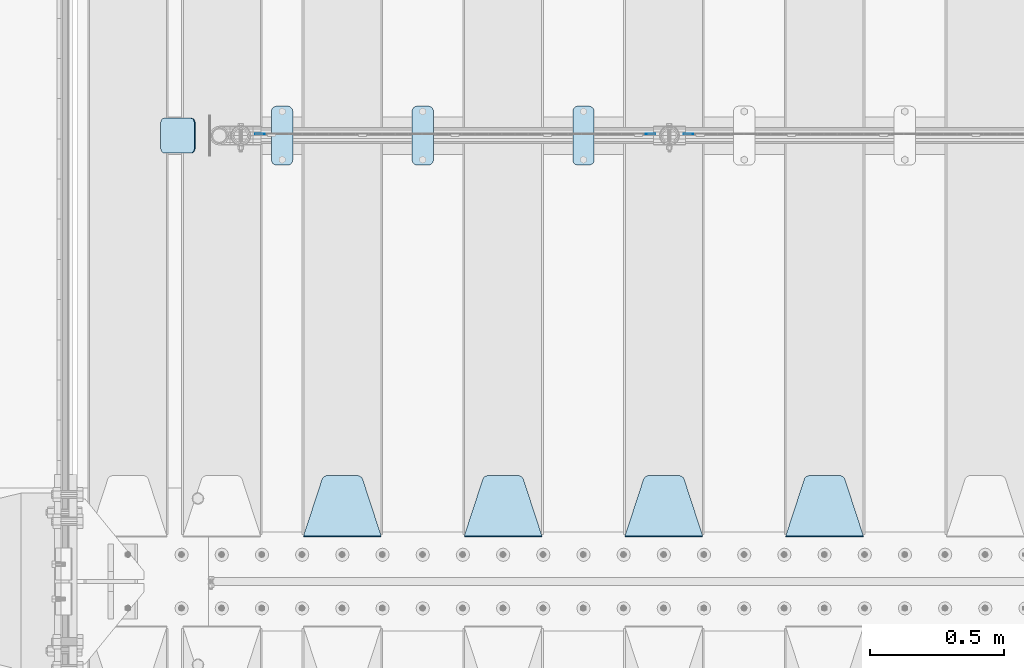
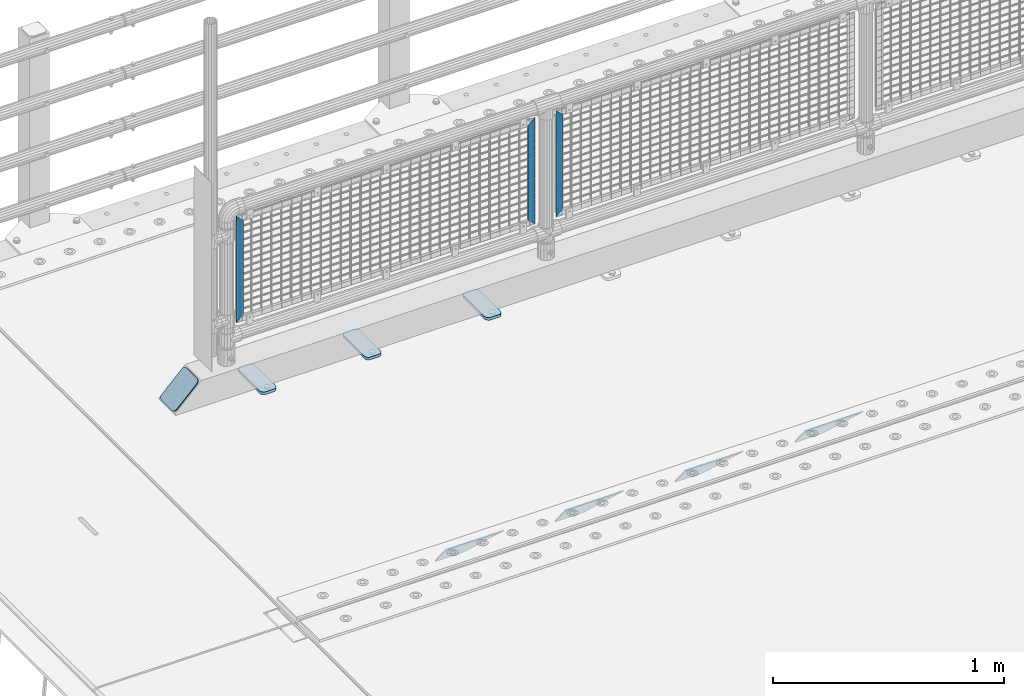
# One storey, part 218 of 257: 11 plates.
"""IFC2X3 building model written with IfcOpenShell, lengths in millimetres."""

from ifc_helpers import new_model, si_unit, frame, origin_with_axes, place, context, subcontext, project, spatial, faceted_brep, material, type_object, element, save


model = new_model("IFC2X3")

# Units and contexts
model_context = context("Model", 3, precision=1e-05, world=origin_with_axes())
body_context = subcontext(model_context, "Body", "Model", "MODEL_VIEW")
ifc_project = project(units=[si_unit("LENGTHUNIT", "METRE", prefix="MILLI"), si_unit("AREAUNIT", "SQUARE_METRE"), si_unit("VOLUMEUNIT", "CUBIC_METRE"), si_unit("MASSUNIT", "GRAM", prefix="KILO"), si_unit("TIMEUNIT", "SECOND"), si_unit("PLANEANGLEUNIT", "RADIAN"), si_unit("SOLIDANGLEUNIT", "STERADIAN"), si_unit("THERMODYNAMICTEMPERATUREUNIT", "DEGREE_CELSIUS"), si_unit("LUMINOUSINTENSITYUNIT", "LUMEN")], contexts=[model_context])

# Site, building, storey
site_placement = place(None, origin_with_axes())
site = spatial("IfcSite", under=ifc_project, at=site_placement, CompositionType="ELEMENT")
building_placement = place(site_placement, origin_with_axes())
building = spatial("IfcBuilding", under=site, at=building_placement, Name="Standard", CompositionType="ELEMENT")
storey_placement = place(building_placement, origin_with_axes())
storey = spatial("IfcBuildingStorey", under=building, at=storey_placement, Name="Undefined", CompositionType="ELEMENT", Elevation=0.0)

# Plates
ifc_material_1 = material(Name="STEEL/S355J2")
plate_type_1 = type_object("IfcPlateType", PredefinedType="NOTDEFINED")
plate_1_placement = place(storey_placement, frame((44310.0, 10774.5, 21.0199999999977), z_axis=(1.0, 0.0, 0.0), x_axis=(0.0, -1.0, 0.0)))
element("IfcPlate", 1, at=plate_1_placement, inside=storey, type_object=plate_type_1, material=ifc_material_1, context=body_context, shape_type="Brep", body=[
    faceted_brep([(0.0, -7.0, 20.0), (0.0, -7.0, 60.0), (0.0, 7.0, 60.0), (0.0, 7.0, 20.0), (0.384294391935327, -7.0, 63.9018064403208), (0.384294391935327, 7.0, 63.9018064403208), (1.52240934977453, -7.0, 67.6536686473046), (1.52240934977453, 7.0, 67.6536686473046), (3.37060775394821, -7.0, 71.1114046603907), (3.37060775394821, 7.0, 71.1114046603907), (5.85786437626848, -7.0, 74.1421356237333), (5.85786437626848, 7.0, 74.1421356237333), (8.88859533960749, -7.0, 76.6293922460536), (8.88859533960749, 7.0, 76.6293922460536), (12.3463313526991, -7.0, 78.4775906502255), (12.3463313526991, 7.0, 78.4775906502255), (16.0981935596774, -7.0, 79.6157056080629), (16.0981935596774, 7.0, 79.6157056080629), (20.0, -7.0, 80.0), (20.0, 7.0, 80.0), (200.0, -7.0, 80.0), (200.0, 7.0, 80.0), (203.901806440323, -7.0, 79.6157056080629), (203.901806440323, 7.0, 79.6157056080629), (207.653668647301, -7.0, 78.4775906502255), (207.653668647301, 7.0, 78.4775906502255), (211.111404660393, -7.0, 76.6293922460536), (211.111404660393, 7.0, 76.6293922460536), (214.142135623732, -7.0, 74.1421356237333), (214.142135623732, 7.0, 74.1421356237333), (216.629392246052, -7.0, 71.1114046603907), (216.629392246052, 7.0, 71.1114046603907), (218.477590650225, -7.0, 67.6536686473046), (218.477590650225, 7.0, 67.6536686473046), (219.615705608065, -7.0, 63.9018064403208), (219.615705608065, 7.0, 63.9018064403208), (220.0, -7.0, 60.0), (220.0, 7.0, 60.0), (220.0, -7.0, 20.0), (220.0, 7.0, 20.0), (219.615705608065, -7.0, 16.0981935596792), (219.615705608065, 7.0, 16.0981935596792), (218.477590650225, -7.0, 12.3463313526954), (218.477590650225, 7.0, 12.3463313526954), (216.629392246052, -7.0, 8.88859533960931), (216.629392246052, 7.0, 8.88859533960931), (214.142135623732, -7.0, 5.85786437626666), (214.142135623732, 7.0, 5.85786437626666), (211.111404660393, -7.0, 3.37060775394639), (211.111404660393, 7.0, 3.37060775394639), (207.653668647301, -7.0, 1.52240934977453), (207.653668647301, 7.0, 1.52240934977453), (203.901806440323, -7.0, 0.384294391937146), (203.901806440323, 7.0, 0.384294391937146), (200.0, -7.0, 0.0), (200.0, 7.0, 0.0), (20.0, -7.0, 0.0), (20.0, 7.0, 0.0), (16.0981935596774, -7.0, 0.384294391937146), (16.0981935596774, 7.0, 0.384294391937146), (12.3463313526991, -7.0, 1.52240934977453), (12.3463313526991, 7.0, 1.52240934977453), (8.88859533960749, -7.0, 3.37060775394639), (8.88859533960749, 7.0, 3.37060775394639), (5.85786437626848, -7.0, 5.85786437626666), (5.85786437626848, 7.0, 5.85786437626666), (3.37060775394821, -7.0, 8.88859533960931), (3.37060775394821, 7.0, 8.88859533960931), (1.52240934977453, -7.0, 12.3463313526954), (1.52240934977453, 7.0, 12.3463313526954), (0.384294391935327, -7.0, 16.0981935596792), (0.384294391935327, 7.0, 16.0981935596792)], [[[0, 1, 2, 3]], [[1, 4, 5, 2]], [[4, 6, 7, 5]], [[6, 8, 9, 7]], [[8, 10, 11, 9]], [[10, 12, 13, 11]], [[12, 14, 15, 13]], [[14, 16, 17, 15]], [[16, 18, 19, 17]], [[18, 20, 21, 19]], [[20, 22, 23, 21]], [[22, 24, 25, 23]], [[24, 26, 27, 25]], [[26, 28, 29, 27]], [[28, 30, 31, 29]], [[30, 32, 33, 31]], [[32, 34, 35, 33]], [[34, 36, 37, 35]], [[36, 38, 39, 37]], [[38, 40, 41, 39]], [[40, 42, 43, 41]], [[42, 44, 45, 43]], [[44, 46, 47, 45]], [[46, 48, 49, 47]], [[48, 50, 51, 49]], [[50, 52, 53, 51]], [[52, 54, 55, 53]], [[54, 56, 57, 55]], [[56, 58, 59, 57]], [[58, 60, 61, 59]], [[60, 62, 63, 61]], [[62, 64, 65, 63]], [[64, 66, 67, 65]], [[66, 68, 69, 67]], [[68, 70, 71, 69]], [[70, 0, 3, 71]], [[5, 7, 9, 11, 13, 15, 17, 19, 21, 23, 25, 27, 29, 31, 33, 35, 37, 39, 41, 43, 45, 47, 49, 51, 53, 55, 57, 59, 61, 63, 65, 67, 69, 71, 3, 2]], [[70, 68, 66, 64, 62, 60, 58, 56, 54, 52, 50, 48, 46, 44, 42, 40, 38, 36, 34, 32, 30, 28, 26, 24, 22, 20, 18, 16, 14, 12, 10, 8, 6, 4, 1, 0]]]),
])
plate_2_placement = place(storey_placement, frame((43710.0, 10774.5, 21.0199999999977), z_axis=(1.0, 0.0, 0.0), x_axis=(0.0, -1.0, 0.0)))
element("IfcPlate", 2, at=plate_2_placement, inside=storey, type_object=plate_type_1, material=ifc_material_1, context=body_context, shape_type="Brep", body=[
    faceted_brep([(0.0, -7.0, 20.0), (0.0, -7.0, 60.0), (0.0, 7.0, 60.0), (0.0, 7.0, 20.0), (0.384294391935327, -7.0, 63.9018064403208), (0.384294391935327, 7.0, 63.9018064403208), (1.52240934977453, -7.0, 67.6536686473046), (1.52240934977453, 7.0, 67.6536686473046), (3.37060775394821, -7.0, 71.1114046603907), (3.37060775394821, 7.0, 71.1114046603907), (5.85786437626848, -7.0, 74.1421356237333), (5.85786437626848, 7.0, 74.1421356237333), (8.88859533960749, -7.0, 76.6293922460536), (8.88859533960749, 7.0, 76.6293922460536), (12.3463313526991, -7.0, 78.4775906502255), (12.3463313526991, 7.0, 78.4775906502255), (16.0981935596774, -7.0, 79.6157056080629), (16.0981935596774, 7.0, 79.6157056080629), (20.0, -7.0, 80.0), (20.0, 7.0, 80.0), (200.0, -7.0, 80.0), (200.0, 7.0, 80.0), (203.901806440323, -7.0, 79.6157056080629), (203.901806440323, 7.0, 79.6157056080629), (207.653668647301, -7.0, 78.4775906502255), (207.653668647301, 7.0, 78.4775906502255), (211.111404660393, -7.0, 76.6293922460536), (211.111404660393, 7.0, 76.6293922460536), (214.142135623732, -7.0, 74.1421356237333), (214.142135623732, 7.0, 74.1421356237333), (216.629392246052, -7.0, 71.1114046603907), (216.629392246052, 7.0, 71.1114046603907), (218.477590650225, -7.0, 67.6536686473046), (218.477590650225, 7.0, 67.6536686473046), (219.615705608065, -7.0, 63.9018064403208), (219.615705608065, 7.0, 63.9018064403208), (220.0, -7.0, 60.0), (220.0, 7.0, 60.0), (220.0, -7.0, 20.0), (220.0, 7.0, 20.0), (219.615705608065, -7.0, 16.0981935596792), (219.615705608065, 7.0, 16.0981935596792), (218.477590650225, -7.0, 12.3463313526954), (218.477590650225, 7.0, 12.3463313526954), (216.629392246052, -7.0, 8.88859533960931), (216.629392246052, 7.0, 8.88859533960931), (214.142135623732, -7.0, 5.85786437626666), (214.142135623732, 7.0, 5.85786437626666), (211.111404660393, -7.0, 3.37060775394639), (211.111404660393, 7.0, 3.37060775394639), (207.653668647301, -7.0, 1.52240934977453), (207.653668647301, 7.0, 1.52240934977453), (203.901806440323, -7.0, 0.384294391937146), (203.901806440323, 7.0, 0.384294391937146), (200.0, -7.0, 0.0), (200.0, 7.0, 0.0), (20.0, -7.0, 0.0), (20.0, 7.0, 0.0), (16.0981935596774, -7.0, 0.384294391937146), (16.0981935596774, 7.0, 0.384294391937146), (12.3463313526991, -7.0, 1.52240934977453), (12.3463313526991, 7.0, 1.52240934977453), (8.88859533960749, -7.0, 3.37060775394639), (8.88859533960749, 7.0, 3.37060775394639), (5.85786437626848, -7.0, 5.85786437626666), (5.85786437626848, 7.0, 5.85786437626666), (3.37060775394821, -7.0, 8.88859533960931), (3.37060775394821, 7.0, 8.88859533960931), (1.52240934977453, -7.0, 12.3463313526954), (1.52240934977453, 7.0, 12.3463313526954), (0.384294391935327, -7.0, 16.0981935596792), (0.384294391935327, 7.0, 16.0981935596792)], [[[0, 1, 2, 3]], [[1, 4, 5, 2]], [[4, 6, 7, 5]], [[6, 8, 9, 7]], [[8, 10, 11, 9]], [[10, 12, 13, 11]], [[12, 14, 15, 13]], [[14, 16, 17, 15]], [[16, 18, 19, 17]], [[18, 20, 21, 19]], [[20, 22, 23, 21]], [[22, 24, 25, 23]], [[24, 26, 27, 25]], [[26, 28, 29, 27]], [[28, 30, 31, 29]], [[30, 32, 33, 31]], [[32, 34, 35, 33]], [[34, 36, 37, 35]], [[36, 38, 39, 37]], [[38, 40, 41, 39]], [[40, 42, 43, 41]], [[42, 44, 45, 43]], [[44, 46, 47, 45]], [[46, 48, 49, 47]], [[48, 50, 51, 49]], [[50, 52, 53, 51]], [[52, 54, 55, 53]], [[54, 56, 57, 55]], [[56, 58, 59, 57]], [[58, 60, 61, 59]], [[60, 62, 63, 61]], [[62, 64, 65, 63]], [[64, 66, 67, 65]], [[66, 68, 69, 67]], [[68, 70, 71, 69]], [[70, 0, 3, 71]], [[5, 7, 9, 11, 13, 15, 17, 19, 21, 23, 25, 27, 29, 31, 33, 35, 37, 39, 41, 43, 45, 47, 49, 51, 53, 55, 57, 59, 61, 63, 65, 67, 69, 71, 3, 2]], [[70, 68, 66, 64, 62, 60, 58, 56, 54, 52, 50, 48, 46, 44, 42, 40, 38, 36, 34, 32, 30, 28, 26, 24, 22, 20, 18, 16, 14, 12, 10, 8, 6, 4, 1, 0]]]),
])
plate_3_placement = place(storey_placement, frame((43185.0, 10774.5, 21.0199999999977), z_axis=(1.0, 0.0, 0.0), x_axis=(0.0, -1.0, 0.0)))
element("IfcPlate", 3, at=plate_3_placement, inside=storey, type_object=plate_type_1, material=ifc_material_1, context=body_context, shape_type="Brep", body=[
    faceted_brep([(0.0, -7.0, 20.0), (0.0, -7.0, 60.0), (0.0, 7.0, 60.0), (0.0, 7.0, 20.0), (0.384294391935327, -7.0, 63.9018064403208), (0.384294391935327, 7.0, 63.9018064403208), (1.52240934977453, -7.0, 67.6536686473046), (1.52240934977453, 7.0, 67.6536686473046), (3.37060775394821, -7.0, 71.1114046603907), (3.37060775394821, 7.0, 71.1114046603907), (5.85786437626848, -7.0, 74.1421356237333), (5.85786437626848, 7.0, 74.1421356237333), (8.88859533960749, -7.0, 76.6293922460536), (8.88859533960749, 7.0, 76.6293922460536), (12.3463313526991, -7.0, 78.4775906502255), (12.3463313526991, 7.0, 78.4775906502255), (16.0981935596774, -7.0, 79.6157056080629), (16.0981935596774, 7.0, 79.6157056080629), (20.0, -7.0, 80.0), (20.0, 7.0, 80.0), (200.0, -7.0, 80.0), (200.0, 7.0, 80.0), (203.901806440323, -7.0, 79.6157056080629), (203.901806440323, 7.0, 79.6157056080629), (207.653668647301, -7.0, 78.4775906502255), (207.653668647301, 7.0, 78.4775906502255), (211.111404660393, -7.0, 76.6293922460536), (211.111404660393, 7.0, 76.6293922460536), (214.142135623732, -7.0, 74.1421356237333), (214.142135623732, 7.0, 74.1421356237333), (216.629392246052, -7.0, 71.1114046603907), (216.629392246052, 7.0, 71.1114046603907), (218.477590650225, -7.0, 67.6536686473046), (218.477590650225, 7.0, 67.6536686473046), (219.615705608065, -7.0, 63.9018064403208), (219.615705608065, 7.0, 63.9018064403208), (220.0, -7.0, 60.0), (220.0, 7.0, 60.0), (220.0, -7.0, 20.0), (220.0, 7.0, 20.0), (219.615705608065, -7.0, 16.0981935596792), (219.615705608065, 7.0, 16.0981935596792), (218.477590650225, -7.0, 12.3463313526954), (218.477590650225, 7.0, 12.3463313526954), (216.629392246052, -7.0, 8.88859533960931), (216.629392246052, 7.0, 8.88859533960931), (214.142135623732, -7.0, 5.85786437626666), (214.142135623732, 7.0, 5.85786437626666), (211.111404660393, -7.0, 3.37060775394639), (211.111404660393, 7.0, 3.37060775394639), (207.653668647301, -7.0, 1.52240934977453), (207.653668647301, 7.0, 1.52240934977453), (203.901806440323, -7.0, 0.384294391937146), (203.901806440323, 7.0, 0.384294391937146), (200.0, -7.0, 0.0), (200.0, 7.0, 0.0), (20.0, -7.0, 0.0), (20.0, 7.0, 0.0), (16.0981935596774, -7.0, 0.384294391937146), (16.0981935596774, 7.0, 0.384294391937146), (12.3463313526991, -7.0, 1.52240934977453), (12.3463313526991, 7.0, 1.52240934977453), (8.88859533960749, -7.0, 3.37060775394639), (8.88859533960749, 7.0, 3.37060775394639), (5.85786437626848, -7.0, 5.85786437626666), (5.85786437626848, 7.0, 5.85786437626666), (3.37060775394821, -7.0, 8.88859533960931), (3.37060775394821, 7.0, 8.88859533960931), (1.52240934977453, -7.0, 12.3463313526954), (1.52240934977453, 7.0, 12.3463313526954), (0.384294391935327, -7.0, 16.0981935596792), (0.384294391935327, 7.0, 16.0981935596792)], [[[0, 1, 2, 3]], [[1, 4, 5, 2]], [[4, 6, 7, 5]], [[6, 8, 9, 7]], [[8, 10, 11, 9]], [[10, 12, 13, 11]], [[12, 14, 15, 13]], [[14, 16, 17, 15]], [[16, 18, 19, 17]], [[18, 20, 21, 19]], [[20, 22, 23, 21]], [[22, 24, 25, 23]], [[24, 26, 27, 25]], [[26, 28, 29, 27]], [[28, 30, 31, 29]], [[30, 32, 33, 31]], [[32, 34, 35, 33]], [[34, 36, 37, 35]], [[36, 38, 39, 37]], [[38, 40, 41, 39]], [[40, 42, 43, 41]], [[42, 44, 45, 43]], [[44, 46, 47, 45]], [[46, 48, 49, 47]], [[48, 50, 51, 49]], [[50, 52, 53, 51]], [[52, 54, 55, 53]], [[54, 56, 57, 55]], [[56, 58, 59, 57]], [[58, 60, 61, 59]], [[60, 62, 63, 61]], [[62, 64, 65, 63]], [[64, 66, 67, 65]], [[66, 68, 69, 67]], [[68, 70, 71, 69]], [[70, 0, 3, 71]], [[5, 7, 9, 11, 13, 15, 17, 19, 21, 23, 25, 27, 29, 31, 33, 35, 37, 39, 41, 43, 45, 47, 49, 51, 53, 55, 57, 59, 61, 63, 65, 67, 69, 71, 3, 2]], [[70, 68, 66, 64, 62, 60, 58, 56, 54, 52, 50, 48, 46, 44, 42, 40, 38, 36, 34, 32, 30, 28, 26, 24, 22, 20, 18, 16, 14, 12, 10, 8, 6, 4, 1, 0]]]),
])
ifc_material_2 = material(Name="STEEL/S355N")
plate_type_2 = type_object("IfcPlateType", PredefinedType="NOTDEFINED")
plate_4_placement = place(storey_placement, frame((45395.0, 9168.23223304703, -1.76776695296758), z_axis=(0.0, 0.707106781186547, -0.707106781186548), x_axis=(-1.0, 0.0, 0.0)))
element("IfcPlate", 4, at=plate_4_placement, inside=storey, type_object=plate_type_2, material=ifc_material_2, context=body_context, shape_type="Brep", body=[
    faceted_brep([(0.0, -2.5, 0.0), (69.345504679477, -2.50000000000091, 300.17173142483), (69.345504679477, 2.5, 300.171731424831), (0.0, 2.5, 0.0), (70.927406119954, -2.50000000000091, 304.8974424154), (70.927406119954, 2.5, 304.8974424154), (73.3818627772271, -2.50000000000091, 309.234538108527), (73.3818627772271, 2.49999999999909, 309.234538108527), (76.6187032999587, -2.5, 313.023683126103), (76.6187032999587, 2.5, 313.023683126103), (80.5190132705029, -2.5, 316.125672595372), (80.5190132705029, 2.5, 316.125672595371), (84.9395038596849, -2.5, 318.426546230476), (84.9395038596849, 2.5, 318.426546230477), (89.7177759439219, -2.5, 319.841774983275), (89.7177759439219, 2.5, 319.841774983275), (94.6782862926484, -2.5, 320.319366455079), (94.6782862926484, 2.5, 320.319366455079), (195.321713707352, -2.5, 320.319366455079), (195.321713707352, 2.5, 320.319366455079), (200.282224056078, -2.5, 319.841774983275), (200.282224056078, 2.49999999999909, 319.841774983275), (205.060496140315, -2.5, 318.426546230476), (205.060496140315, 2.49999999999909, 318.426546230475), (209.480986729497, -2.5, 316.125672595371), (209.480986729497, 2.5, 316.125672595371), (213.381296700041, -2.50000000000091, 313.023683126102), (213.381296700041, 2.5, 313.023683126103), (216.618137222766, -2.50000000000091, 309.234538108527), (216.618137222766, 2.5, 309.234538108527), (219.072593880039, -2.5, 304.897442415399), (219.072593880039, 2.5, 304.897442415399), (220.654495320523, -2.50000000000091, 300.17173142483), (220.654495320523, 2.5, 300.171731424831), (290.0, -2.50000000000091, 0.0), (290.0, 2.5, 9.09494701772928e-13)], [[[0, 1, 2, 3]], [[1, 4, 5, 2]], [[4, 6, 7, 5]], [[6, 8, 9, 7]], [[8, 10, 11, 9]], [[10, 12, 13, 11]], [[12, 14, 15, 13]], [[14, 16, 17, 15]], [[16, 18, 19, 17]], [[18, 20, 21, 19]], [[20, 22, 23, 21]], [[22, 24, 25, 23]], [[24, 26, 27, 25]], [[26, 28, 29, 27]], [[28, 30, 31, 29]], [[30, 32, 33, 31]], [[32, 34, 35, 33]], [[34, 0, 3, 35]], [[5, 7, 9, 11, 13, 15, 17, 19, 21, 23, 25, 27, 29, 31, 33, 35, 3, 2]], [[34, 32, 30, 28, 26, 24, 22, 20, 18, 16, 14, 12, 10, 8, 6, 4, 1, 0]]]),
])
plate_5_placement = place(storey_placement, frame((44795.0, 9168.23223304703, -1.76776695296758), z_axis=(0.0, 0.707106781186547, -0.707106781186548), x_axis=(-1.0, 0.0, 0.0)))
element("IfcPlate", 5, at=plate_5_placement, inside=storey, type_object=plate_type_2, material=ifc_material_2, context=body_context, shape_type="Brep", body=[
    faceted_brep([(0.0, -2.5, 0.0), (69.345504679477, -2.50000000000091, 300.17173142483), (69.345504679477, 2.5, 300.171731424831), (0.0, 2.5, 0.0), (70.927406119954, -2.50000000000091, 304.8974424154), (70.927406119954, 2.5, 304.8974424154), (73.3818627772271, -2.50000000000091, 309.234538108527), (73.3818627772271, 2.49999999999909, 309.234538108527), (76.6187032999587, -2.5, 313.023683126103), (76.6187032999587, 2.5, 313.023683126103), (80.5190132705029, -2.5, 316.125672595372), (80.5190132705029, 2.5, 316.125672595371), (84.9395038596849, -2.5, 318.426546230476), (84.9395038596849, 2.5, 318.426546230477), (89.7177759439219, -2.5, 319.841774983275), (89.7177759439219, 2.5, 319.841774983275), (94.6782862926484, -2.5, 320.319366455079), (94.6782862926484, 2.5, 320.319366455079), (195.321713707352, -2.5, 320.319366455079), (195.321713707352, 2.5, 320.319366455079), (200.282224056078, -2.5, 319.841774983275), (200.282224056078, 2.49999999999909, 319.841774983275), (205.060496140315, -2.5, 318.426546230476), (205.060496140315, 2.49999999999909, 318.426546230475), (209.480986729497, -2.5, 316.125672595371), (209.480986729497, 2.5, 316.125672595371), (213.381296700041, -2.50000000000091, 313.023683126102), (213.381296700041, 2.5, 313.023683126103), (216.618137222766, -2.50000000000091, 309.234538108527), (216.618137222766, 2.5, 309.234538108527), (219.072593880039, -2.5, 304.897442415399), (219.072593880039, 2.5, 304.897442415399), (220.654495320523, -2.50000000000091, 300.17173142483), (220.654495320523, 2.5, 300.171731424831), (290.0, -2.50000000000091, 0.0), (290.0, 2.5, 9.09494701772928e-13)], [[[0, 1, 2, 3]], [[1, 4, 5, 2]], [[4, 6, 7, 5]], [[6, 8, 9, 7]], [[8, 10, 11, 9]], [[10, 12, 13, 11]], [[12, 14, 15, 13]], [[14, 16, 17, 15]], [[16, 18, 19, 17]], [[18, 20, 21, 19]], [[20, 22, 23, 21]], [[22, 24, 25, 23]], [[24, 26, 27, 25]], [[26, 28, 29, 27]], [[28, 30, 31, 29]], [[30, 32, 33, 31]], [[32, 34, 35, 33]], [[34, 0, 3, 35]], [[5, 7, 9, 11, 13, 15, 17, 19, 21, 23, 25, 27, 29, 31, 33, 35, 3, 2]], [[34, 32, 30, 28, 26, 24, 22, 20, 18, 16, 14, 12, 10, 8, 6, 4, 1, 0]]]),
])
plate_6_placement = place(storey_placement, frame((44195.0, 9168.23223304703, -1.76776695296758), z_axis=(0.0, 0.707106781186547, -0.707106781186548), x_axis=(-1.0, 0.0, 0.0)))
element("IfcPlate", 6, at=plate_6_placement, inside=storey, type_object=plate_type_2, material=ifc_material_2, context=body_context, shape_type="Brep", body=[
    faceted_brep([(0.0, -2.5, 0.0), (69.345504679477, -2.50000000000091, 300.17173142483), (69.345504679477, 2.5, 300.171731424831), (0.0, 2.5, 0.0), (70.927406119954, -2.50000000000091, 304.8974424154), (70.927406119954, 2.5, 304.8974424154), (73.3818627772271, -2.50000000000091, 309.234538108527), (73.3818627772271, 2.49999999999909, 309.234538108527), (76.6187032999587, -2.5, 313.023683126103), (76.6187032999587, 2.5, 313.023683126103), (80.5190132705029, -2.5, 316.125672595372), (80.5190132705029, 2.5, 316.125672595371), (84.9395038596849, -2.5, 318.426546230476), (84.9395038596849, 2.5, 318.426546230477), (89.7177759439219, -2.5, 319.841774983275), (89.7177759439219, 2.5, 319.841774983275), (94.6782862926484, -2.5, 320.319366455079), (94.6782862926484, 2.5, 320.319366455079), (195.321713707352, -2.5, 320.319366455079), (195.321713707352, 2.5, 320.319366455079), (200.282224056078, -2.5, 319.841774983275), (200.282224056078, 2.49999999999909, 319.841774983275), (205.060496140315, -2.5, 318.426546230476), (205.060496140315, 2.49999999999909, 318.426546230475), (209.480986729497, -2.5, 316.125672595371), (209.480986729497, 2.5, 316.125672595371), (213.381296700041, -2.50000000000091, 313.023683126102), (213.381296700041, 2.5, 313.023683126103), (216.618137222766, -2.50000000000091, 309.234538108527), (216.618137222766, 2.5, 309.234538108527), (219.072593880039, -2.5, 304.897442415399), (219.072593880039, 2.5, 304.897442415399), (220.654495320523, -2.50000000000091, 300.17173142483), (220.654495320523, 2.5, 300.171731424831), (290.0, -2.50000000000091, 0.0), (290.0, 2.5, 9.09494701772928e-13)], [[[0, 1, 2, 3]], [[1, 4, 5, 2]], [[4, 6, 7, 5]], [[6, 8, 9, 7]], [[8, 10, 11, 9]], [[10, 12, 13, 11]], [[12, 14, 15, 13]], [[14, 16, 17, 15]], [[16, 18, 19, 17]], [[18, 20, 21, 19]], [[20, 22, 23, 21]], [[22, 24, 25, 23]], [[24, 26, 27, 25]], [[26, 28, 29, 27]], [[28, 30, 31, 29]], [[30, 32, 33, 31]], [[32, 34, 35, 33]], [[34, 0, 3, 35]], [[5, 7, 9, 11, 13, 15, 17, 19, 21, 23, 25, 27, 29, 31, 33, 35, 3, 2]], [[34, 32, 30, 28, 26, 24, 22, 20, 18, 16, 14, 12, 10, 8, 6, 4, 1, 0]]]),
])
plate_7_placement = place(storey_placement, frame((43595.0, 9168.23223304703, -1.76776695296758), z_axis=(0.0, 0.707106781186547, -0.707106781186548), x_axis=(-1.0, 0.0, 0.0)))
element("IfcPlate", 7, at=plate_7_placement, inside=storey, type_object=plate_type_2, material=ifc_material_2, context=body_context, shape_type="Brep", body=[
    faceted_brep([(0.0, -2.5, 0.0), (69.345504679477, -2.50000000000091, 300.17173142483), (69.345504679477, 2.5, 300.171731424831), (0.0, 2.5, 0.0), (70.927406119954, -2.50000000000091, 304.8974424154), (70.927406119954, 2.5, 304.8974424154), (73.3818627772271, -2.50000000000091, 309.234538108527), (73.3818627772271, 2.49999999999909, 309.234538108527), (76.6187032999587, -2.5, 313.023683126103), (76.6187032999587, 2.5, 313.023683126103), (80.5190132705029, -2.5, 316.125672595372), (80.5190132705029, 2.5, 316.125672595371), (84.9395038596849, -2.5, 318.426546230476), (84.9395038596849, 2.5, 318.426546230477), (89.7177759439219, -2.5, 319.841774983275), (89.7177759439219, 2.5, 319.841774983275), (94.6782862926484, -2.5, 320.319366455079), (94.6782862926484, 2.5, 320.319366455079), (195.321713707352, -2.5, 320.319366455079), (195.321713707352, 2.5, 320.319366455079), (200.282224056078, -2.5, 319.841774983275), (200.282224056078, 2.49999999999909, 319.841774983275), (205.060496140315, -2.5, 318.426546230476), (205.060496140315, 2.49999999999909, 318.426546230475), (209.480986729497, -2.5, 316.125672595371), (209.480986729497, 2.5, 316.125672595371), (213.381296700041, -2.50000000000091, 313.023683126102), (213.381296700041, 2.5, 313.023683126103), (216.618137222766, -2.50000000000091, 309.234538108527), (216.618137222766, 2.5, 309.234538108527), (219.072593880039, -2.5, 304.897442415399), (219.072593880039, 2.5, 304.897442415399), (220.654495320523, -2.50000000000091, 300.17173142483), (220.654495320523, 2.5, 300.171731424831), (290.0, -2.50000000000091, 0.0), (290.0, 2.5, 9.09494701772928e-13)], [[[0, 1, 2, 3]], [[1, 4, 5, 2]], [[4, 6, 7, 5]], [[6, 8, 9, 7]], [[8, 10, 11, 9]], [[10, 12, 13, 11]], [[12, 14, 15, 13]], [[14, 16, 17, 15]], [[16, 18, 19, 17]], [[18, 20, 21, 19]], [[20, 22, 23, 21]], [[22, 24, 25, 23]], [[24, 26, 27, 25]], [[26, 28, 29, 27]], [[28, 30, 31, 29]], [[30, 32, 33, 31]], [[32, 34, 35, 33]], [[34, 0, 3, 35]], [[5, 7, 9, 11, 13, 15, 17, 19, 21, 23, 25, 27, 29, 31, 33, 35, 3, 2]], [[34, 32, 30, 28, 26, 24, 22, 20, 18, 16, 14, 12, 10, 8, 6, 4, 1, 0]]]),
])
ifc_material_3 = material(Name="Misc_Undefined")
plate_type_3 = type_object("IfcPlateType", PredefinedType="NOTDEFINED")
for number, where, z_axis, x_axis in (
    (8, (44759.509713541, 10670.5, 879.519963133601), (-0.707008801899317, 0.0, -0.707204746899292), (-0.707204746899293, 0.0, 0.707008801899317)),
    (9, (43159.509713541, 10670.5, 879.519963133601), (-0.707008801899317, 0.0, -0.707204746899292), (-0.707204746899293, 0.0, 0.707008801899317)),
):
    element("IfcPlate", number, at=place(storey_placement, frame(where, z_axis=z_axis, x_axis=x_axis)), inside=storey, type_object=plate_type_3, material=ifc_material_3, context=body_context, shape_type="Brep", body=[
        faceted_brep([(0.0, -1.5, -5.6843418860808e-14), (-348.552185058586, -1.5, 348.655029296868), (-348.552185058586, 1.5, 348.655029296868), (0.0, 1.5, -5.6843418860808e-14), (-348.544891357407, -1.5, 398.152496337891), (-348.544891357407, 1.5, 398.152496337891), (49.5043945312573, -1.5, 7.27595761418343e-11), (49.5043945312573, 1.5, 7.27595761418343e-11)], [[[0, 1, 2, 3]], [[1, 4, 5, 2]], [[4, 6, 7, 5]], [[6, 0, 3, 7]], [[5, 7, 3, 2]], [[6, 4, 1, 0]]]),
    ])
plate_8_placement = place(storey_placement, frame((44582.4996874836, 10670.5, 879.52), z_axis=(0.707103624179501, 0.0, -0.707109938179499), x_axis=(0.707109938179525, 0.0, 0.707103624179475)))
element("IfcPlate", 10, at=plate_8_placement, inside=storey, type_object=plate_type_3, material=ifc_material_3, context=body_context, shape_type="Brep", body=[
    faceted_brep([(0.0, -1.5, -5.6843418860808e-14), (-348.605163574226, -1.5, 348.602081298828), (-348.605163574226, 1.5, 348.602081298828), (0.0, 1.5, -5.6843418860808e-14), (-348.605163574226, -1.5, 398.099334716804), (-348.605163574226, 1.5, 398.099334716804), (49.4976959228443, -1.5, 6.54836185276508e-11), (49.4976959228443, 1.5, 6.54836185276508e-11)], [[[0, 1, 2, 3]], [[1, 4, 5, 2]], [[4, 6, 7, 5]], [[6, 0, 3, 7]], [[5, 7, 3, 2]], [[6, 4, 1, 0]]]),
])
plate_type_4 = type_object("IfcPlateType", PredefinedType="NOTDEFINED")
plate_9_placement = place(storey_placement, frame((42899.807581521, 10729.5, 166.254400376559), z_axis=(-0.707410512925779, 0.0, -0.70680291892584), x_axis=(0.0, -1.0, 0.0)))
element("IfcPlate", 11, at=plate_9_placement, inside=storey, type_object=plate_type_4, material=ifc_material_1, context=body_context, shape_type="Brep", body=[
    faceted_brep([(0.0, -2.49999999999272, 19.9999999999927), (0.0, -2.49999999999272, 158.926651000977), (0.0, 2.50000000001455, 158.926651000969), (0.0, 2.50000000000728, 19.9999999999927), (0.384294391935327, -2.49999999999272, 162.828457441297), (0.384294391935327, 2.50000000000728, 162.828457441297), (1.52240934977453, -2.49999999999272, 166.580319648267), (1.52240934977453, 2.50000000000728, 166.580319648267), (3.37060775394821, -2.5, 170.03805566136), (3.37060775394821, 2.50000000000728, 170.03805566136), (5.85786437626848, -2.49999999999272, 173.068786624703), (5.85786437626848, 2.5, 173.068786624703), (8.88859533960749, -2.49999999999272, 175.556043247016), (8.88859533960749, 2.50000000001455, 175.556043247016), (12.3463313526991, -2.49999999999272, 177.404241651195), (12.3463313526991, 2.50000000000728, 177.404241651195), (16.0981935596774, -2.49999999999272, 178.542356609032), (16.0981935596774, 2.50000000000728, 178.542356609032), (20.0, -2.49999999999272, 178.926651000969), (20.0, 2.50000000000728, 178.926651000969), (110.0, -2.49999999999272, 178.926651000969), (110.0, 2.50000000000728, 178.926651000969), (113.901806440323, -2.49999999999272, 178.542356609032), (113.901806440323, 2.50000000000728, 178.542356609032), (117.653668647301, -2.49999999999272, 177.404241651195), (117.653668647301, 2.50000000000728, 177.404241651195), (121.111404660393, -2.49999999999272, 175.556043247016), (121.111404660393, 2.50000000001455, 175.556043247016), (124.142135623732, -2.49999999999272, 173.068786624703), (124.142135623732, 2.5, 173.068786624703), (126.629392246052, -2.5, 170.03805566136), (126.629392246052, 2.50000000000728, 170.03805566136), (128.477590650225, -2.49999999999272, 166.580319648267), (128.477590650225, 2.50000000000728, 166.580319648267), (129.615705608065, -2.49999999999272, 162.828457441297), (129.615705608065, 2.50000000000728, 162.828457441297), (130.0, -2.49999999999272, 158.926651000977), (130.0, 2.50000000001455, 158.926651000969), (130.0, -2.49999999999272, 19.9999999999927), (130.0, 2.50000000000728, 19.9999999999927), (129.615705608065, -2.49999999999272, 16.0981935596719), (129.615705608065, 2.50000000000728, 16.0981935596719), (128.477590650225, -2.49999999999272, 12.3463313526954), (128.477590650225, 2.50000000000728, 12.3463313526881), (126.629392246052, -2.49999999999272, 8.88859533960203), (126.629392246052, 2.50000000000728, 8.88859533959476), (124.142135623732, -2.49999999999272, 5.85786437626666), (124.142135623732, 2.50000000000728, 5.85786437626666), (121.111404660393, -2.49999999999272, 3.37060775394639), (121.111404660393, 2.50000000000728, 3.37060775393911), (117.653668647301, -2.49999999999272, 1.52240934976726), (117.653668647301, 2.50000000000728, 1.52240934977453), (113.901806440323, -2.49999999999272, 0.38429439192987), (113.901806440323, 2.50000000000728, 0.38429439192987), (110.0, -2.49999999999272, -7.27595761418343e-12), (110.0, 2.50000000000728, -7.27595761418343e-12), (20.0, -2.49999999999272, -7.27595761418343e-12), (20.0, 2.50000000000728, -7.27595761418343e-12), (16.0981935596774, -2.49999999999272, 0.38429439192987), (16.0981935596774, 2.50000000000728, 0.38429439192987), (12.3463313526991, -2.49999999999272, 1.52240934976726), (12.3463313526991, 2.50000000000728, 1.52240934977453), (8.88859533960749, -2.49999999999272, 3.37060775394639), (8.88859533960749, 2.50000000000728, 3.37060775393911), (5.85786437626848, -2.49999999999272, 5.85786437626666), (5.85786437626848, 2.50000000000728, 5.85786437626666), (3.37060775394821, -2.49999999999272, 8.88859533960203), (3.37060775394821, 2.50000000000728, 8.88859533959476), (1.52240934977453, -2.49999999999272, 12.3463313526881), (1.52240934977453, 2.50000000000728, 12.3463313526881), (0.384294391935327, -2.49999999999272, 16.0981935596719), (0.384294391935327, 2.50000000000728, 16.0981935596719)], [[[0, 1, 2, 3]], [[1, 4, 5, 2]], [[4, 6, 7, 5]], [[6, 8, 9, 7]], [[8, 10, 11, 9]], [[10, 12, 13, 11]], [[12, 14, 15, 13]], [[14, 16, 17, 15]], [[16, 18, 19, 17]], [[18, 20, 21, 19]], [[20, 22, 23, 21]], [[22, 24, 25, 23]], [[24, 26, 27, 25]], [[26, 28, 29, 27]], [[28, 30, 31, 29]], [[30, 32, 33, 31]], [[32, 34, 35, 33]], [[34, 36, 37, 35]], [[36, 38, 39, 37]], [[38, 40, 41, 39]], [[40, 42, 43, 41]], [[42, 44, 45, 43]], [[44, 46, 47, 45]], [[46, 48, 49, 47]], [[48, 50, 51, 49]], [[50, 52, 53, 51]], [[52, 54, 55, 53]], [[54, 56, 57, 55]], [[56, 58, 59, 57]], [[58, 60, 61, 59]], [[60, 62, 63, 61]], [[62, 64, 65, 63]], [[64, 66, 67, 65]], [[66, 68, 69, 67]], [[68, 70, 71, 69]], [[70, 0, 3, 71]], [[5, 7, 9, 11, 13, 15, 17, 19, 21, 23, 25, 27, 29, 31, 33, 35, 37, 39, 41, 43, 45, 47, 49, 51, 53, 55, 57, 59, 61, 63, 65, 67, 69, 71, 3, 2]], [[70, 68, 66, 64, 62, 60, 58, 56, 54, 52, 50, 48, 46, 44, 42, 40, 38, 36, 34, 32, 30, 28, 26, 24, 22, 20, 18, 16, 14, 12, 10, 8, 6, 4, 1, 0]]]),
])

save(model, "model.ifc")
